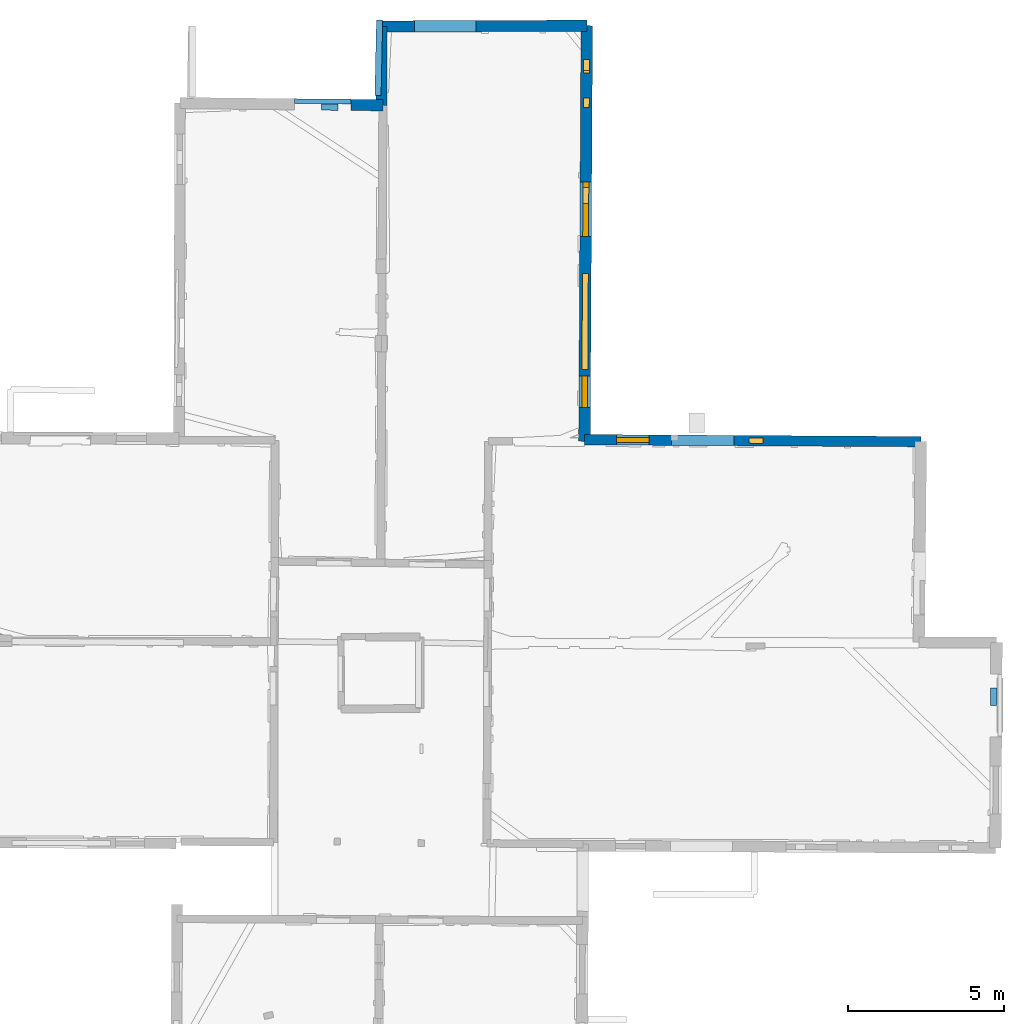
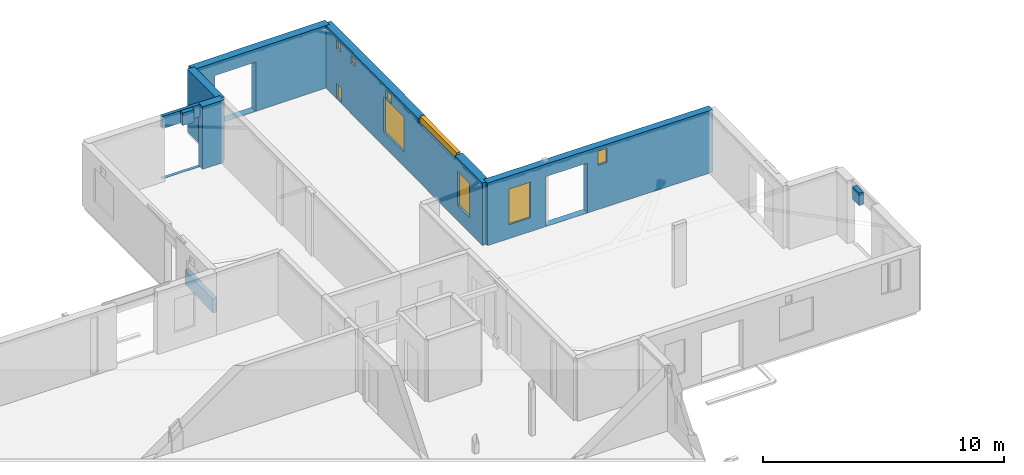
# One storey, part 11 of 17: 9 walls, 9 windows, 12 openings.
"""IFC2X3 building model written with IfcOpenShell, lengths in metres."""

from ifc_helpers import new_model, entity, si_unit, converted_unit, derived_unit, direction, frame, frame_2d, origin, origin_2d_with_axis, place, context, subcontext, project, spatial, polyline, rectangle, outline, extrude, source, transform, mapped, material, layer, layer_set, layer_usage, type_object, type_shapes, element, fill, save


model = new_model("IFC2X3")

# Units and contexts
model_context = context("Model", 3, precision=1e-05, world=origin(), true_north=direction((0.0, 1.0)))
body_context = subcontext(model_context, "Body", "Model", "MODEL_VIEW")
ifc_project = project(units=[si_unit("LENGTHUNIT", "METRE"), si_unit("AREAUNIT", "SQUARE_METRE"), si_unit("VOLUMEUNIT", "CUBIC_METRE"), converted_unit("PLANEANGLEUNIT", "DEGREE", entity("IfcRatioMeasure", 0.0174532925199433), si_unit("PLANEANGLEUNIT", "RADIAN"), dimensions=[0, 0, 0, 0, 0, 0, 0]), si_unit("MASSUNIT", "GRAM", prefix="KILO"), derived_unit("MASSDENSITYUNIT", [(si_unit("MASSUNIT", "GRAM", prefix="KILO"), 1), (si_unit("LENGTHUNIT", "METRE"), -3)]), derived_unit("MOMENTOFINERTIAUNIT", [(si_unit("LENGTHUNIT", "METRE"), 4)]), si_unit("TIMEUNIT", "SECOND"), si_unit("FREQUENCYUNIT", "HERTZ"), si_unit("THERMODYNAMICTEMPERATUREUNIT", "DEGREE_CELSIUS"), derived_unit("THERMALTRANSMITTANCEUNIT", [(si_unit("MASSUNIT", "GRAM", prefix="KILO"), 1), (si_unit("THERMODYNAMICTEMPERATUREUNIT", "KELVIN"), -1), (si_unit("TIMEUNIT", "SECOND"), -3)]), derived_unit("VOLUMETRICFLOWRATEUNIT", [(si_unit("LENGTHUNIT", "METRE"), 3), (si_unit("TIMEUNIT", "SECOND"), -1)]), si_unit("ELECTRICCURRENTUNIT", "AMPERE"), si_unit("ELECTRICVOLTAGEUNIT", "VOLT"), si_unit("POWERUNIT", "WATT"), si_unit("FORCEUNIT", "NEWTON", prefix="KILO"), si_unit("ILLUMINANCEUNIT", "LUX"), si_unit("LUMINOUSFLUXUNIT", "LUMEN"), si_unit("LUMINOUSINTENSITYUNIT", "CANDELA"), derived_unit("USERDEFINED", [(si_unit("MASSUNIT", "GRAM", prefix="KILO"), -1), (si_unit("LENGTHUNIT", "METRE"), -2), (si_unit("TIMEUNIT", "SECOND"), 3), (si_unit("LUMINOUSFLUXUNIT", "LUMEN"), 1)]), derived_unit("LINEARVELOCITYUNIT", [(si_unit("LENGTHUNIT", "METRE"), 1), (si_unit("TIMEUNIT", "SECOND"), -1)]), si_unit("PRESSUREUNIT", "PASCAL"), derived_unit("USERDEFINED", [(si_unit("LENGTHUNIT", "METRE"), -2), (si_unit("MASSUNIT", "GRAM", prefix="KILO"), 1), (si_unit("TIMEUNIT", "SECOND"), -2)]), derived_unit("LINEARFORCEUNIT", [(si_unit("MASSUNIT", "GRAM", prefix="KILO"), 1), (si_unit("LENGTHUNIT", "METRE"), 1), (si_unit("TIMEUNIT", "SECOND"), -2), (si_unit("LENGTHUNIT", "METRE"), -1)]), derived_unit("PLANARFORCEUNIT", [(si_unit("MASSUNIT", "GRAM", prefix="KILO"), 1), (si_unit("LENGTHUNIT", "METRE"), 1), (si_unit("TIMEUNIT", "SECOND"), -2), (si_unit("LENGTHUNIT", "METRE"), -2)])], contexts=[model_context])

# Site, building, storey
placement_1 = place(None, origin())
site = spatial("IfcSite", under=ifc_project, at=placement_1, CompositionType="ELEMENT")
building = spatial("IfcBuilding", under=site, at=placement_1, CompositionType="ELEMENT")
storey_placement = place(placement_1, frame((0.0, 0.0, 5.56662893295288)))
storey = spatial("IfcBuildingStorey", under=building, at=storey_placement, Name="Level 3", CompositionType="ELEMENT", Elevation=5.56662893295288)

# Wall, openings, windows
ifc_material_1 = material(Name="Default wall")
ifc_layer_1 = layer(ifc_material_1, 0.330000013113022)
ifc_layer_set_1 = layer_set([ifc_layer_1], Name="wall_thickness_0.3300")
ifc_layer_usage_1 = layer_usage(ifc_layer_set_1, "AXIS2", "POSITIVE", -0.165000006556511)
wall_type_1 = type_object("IfcWallType", Name="wall_thickness_0.3300", PredefinedType="STANDARD", material=ifc_layer_set_1)
wall_1_placement = place(storey_placement, frame((12.8773711844642, 64.0986976332287, 0.0), z_axis=(0.0, 0.0, 1.0), x_axis=(0.999982570986053, -0.00590404303195194, 0.0)))
wall_1 = element("IfcWallStandardCase", 1, at=wall_1_placement, inside=storey, type_object=wall_type_1, material=ifc_layer_usage_1, Name="Wall:4", ObjectType="Wall", context=body_context, shape_type="SweptSolid", body=[
    extrude(outline(polyline([(10.7565408541965, -0.165000006556511), (10.7565408541965, 0.165000006556511), (0.0, 0.165000006556511), (0.0, -0.165000006556511), (10.7565408541965, -0.165000006556511)])), origin(), (0.0, 0.0, 1.0), 3.16489877700806),
])
opening_1_placement = place(wall_1_placement, frame((2.78610426003413, -0.165000006556511, 0.00537109375)))
element("IfcOpeningElement", 2, at=opening_1_placement, cuts=wall_1, Name="Opening : 1990 x 2520 : 3", ObjectType="Opening", context=body_context, shape_type="SweptSolid", body=[
    extrude(rectangle(XDim=1.99, YDim=2.52, at=frame_2d((1.26, 0.995), x_axis=(0.0, 1.0))), frame((0.0, 0.0, 0.0), z_axis=(0.0, 1.0, 0.0), x_axis=(0.0, 0.0, 1.0)), (0.0, 0.0, 1.0), 0.330000013113022),
])
opening_2_placement = place(wall_1_placement, frame((5.26524771907873, -0.165000006556511, 2.23937082290649)))
opening_2 = element("IfcOpeningElement", 3, at=opening_2_placement, cuts=wall_1, Name="Opening : 445 x 720 : 4", ObjectType="Opening", context=body_context, shape_type="SweptSolid", body=[
    extrude(rectangle(XDim=0.445, YDim=0.72, at=frame_2d((0.36, 0.2225), x_axis=(0.0, 1.0))), frame((0.0, 0.0, 0.0), z_axis=(0.0, 1.0, 0.0), x_axis=(0.0, 0.0, 1.0)), (0.0, 0.0, 1.0), 0.330000013113022),
])
opening_3_placement = place(wall_1_placement, frame((1.02610387296639, -0.165000006556511, 0.705370903015137)))
opening_3 = element("IfcOpeningElement", 4, at=opening_3_placement, cuts=wall_1, Name="Opening : 1035 x 1805 : 5", ObjectType="Opening", context=body_context, shape_type="SweptSolid", body=[
    extrude(rectangle(XDim=1.035, YDim=1.805, at=frame_2d((0.9025, 0.5175), x_axis=(0.0, 1.0))), frame((0.0, 0.0, 0.0), z_axis=(0.0, 1.0, 0.0), x_axis=(0.0, 0.0, 1.0)), (0.0, 0.0, 1.0), 0.330000013113022),
])
ifc_material_2 = material(Name="Window Default")
window_style_1 = type_object("IfcWindowStyle", Name="Window : 445 x 720mm", ConstructionType="NOTDEFINED", OperationType="NOTDEFINED", ParameterTakesPrecedence=False, Sizeable=False, material=ifc_material_2)
shared_shape_1 = source(origin(), body_context, "Body", "SweptSolid", [
    extrude(rectangle(XDim=0.165000006556511, YDim=0.445, at=origin_2d_with_axis()), frame((0.2225, 0.165000006556511, 0.0), z_axis=(0.0, 0.0, 1.0), x_axis=(0.0, 1.0, 0.0)), (0.0, 0.0, 1.0), 0.72),
])
type_shapes(window_style_1, [shared_shape_1])
window_1_placement = place(opening_2_placement, origin())
window_1 = element("IfcWindow", 5, at=window_1_placement, inside=storey, type_object=window_style_1, Name="Window : 445 x 720mm : 1", ObjectType="Window : 445 x 720mm", OverallHeight=0.72, OverallWidth=0.445, context=body_context, shape_type="MappedRepresentation", body=[
    mapped(shared_shape_1, transform((0.0, 0.0, 0.0), scale=1.0)),
])
fill(opening_2, window_1)
window_style_2 = type_object("IfcWindowStyle", Name="Window : 1035 x 1805mm", ConstructionType="NOTDEFINED", OperationType="NOTDEFINED", ParameterTakesPrecedence=False, Sizeable=False, material=ifc_material_2)
shared_shape_2 = source(origin(), body_context, "Body", "SweptSolid", [
    extrude(rectangle(XDim=0.165000006556511, YDim=1.035, at=origin_2d_with_axis()), frame((0.5175, 0.165000006556511, 0.0), z_axis=(0.0, 0.0, 1.0), x_axis=(0.0, 1.0, 0.0)), (0.0, 0.0, 1.0), 1.805),
])
type_shapes(window_style_2, [shared_shape_2])
window_2_placement = place(opening_3_placement, origin())
window_2 = element("IfcWindow", 6, at=window_2_placement, inside=storey, type_object=window_style_2, Name="Window : 1035 x 1805mm : 2", ObjectType="Window : 1035 x 1805mm", OverallHeight=1.805, OverallWidth=1.035, context=body_context, shape_type="MappedRepresentation", body=[
    mapped(shared_shape_2, transform((0.0, 0.0, 0.0), scale=1.0)),
])
fill(opening_3, window_2)

# Walls
ifc_layer_2 = layer(ifc_material_1, 0.2)
ifc_layer_set_2 = layer_set([ifc_layer_2], Name="wall_thickness_0.2000")
ifc_layer_usage_2 = layer_usage(ifc_layer_set_2, "AXIS2", "POSITIVE", -0.1)
wall_type_2 = type_object("IfcWallType", Name="wall_thickness_0.2000", PredefinedType="STANDARD", material=ifc_layer_set_2)
placement_2 = place(placement_1, frame((0.0, 0.0, 8.09899997711182)))
wall_2_placement = place(placement_2, frame((25.9651642169775, 56.1576721431033, 0.0), z_axis=(0.0, 0.0, 1.0), x_axis=(-0.00824713523996844, -0.999965991801888, 0.0)))
element("IfcWallStandardCase", 7, at=wall_2_placement, inside=storey, type_object=wall_type_2, material=ifc_layer_usage_2, Name="Wall:55", ObjectType="Wall", context=body_context, shape_type="SweptSolid", body=[
    extrude(outline(polyline([(0.565002582639686, -0.1), (0.565002582639686, 0.1), (0.0, 0.1), (0.0, -0.1), (0.565002582639686, -0.1)])), origin(), (0.0, 0.0, 1.0), 0.632527732849121),
])
placement_3 = place(placement_1, frame((0.0, 0.0, 8.09899997711182)))
wall_3_placement = place(placement_3, frame((4.46161637524868, 74.7364073292613, 0.0), z_axis=(0.0, 0.0, 1.0), x_axis=(0.999937550432518, -0.0111756536728691, 0.0)))
element("IfcWallStandardCase", 8, at=wall_3_placement, inside=storey, type_object=wall_type_2, material=ifc_layer_usage_2, Name="Wall:91", ObjectType="Wall", context=body_context, shape_type="SweptSolid", body=[
    extrude(outline(polyline([(0.539999829170567, -0.1), (0.539999829170567, 0.1), (0.0, 0.1), (0.0, -0.1), (0.539999829170567, -0.1)])), origin(), (0.0, 0.0, 1.0), 0.632527732849121),
])
placement_4 = place(placement_1, frame((0.0, 0.0, -2.2819995880127)))
wall_4_placement = place(placement_4, frame((6.32514802864819, 77.5169268311821, 0.0), z_axis=(0.0, 0.0, 1.0), x_axis=(-0.0216953788022225, -0.999764627569223, 0.0)))
element("IfcWallStandardCase", 9, at=wall_4_placement, inside=storey, type_object=wall_type_2, material=ifc_layer_usage_2, Name="Wall:854", ObjectType="Wall", context=body_context, shape_type="SweptSolid", body=[
    extrude(outline(polyline([(2.40779329065963, -0.1), (2.40779329065963, 0.1), (0.0, 0.1), (0.0, -0.1), (2.40779329065963, -0.1)])), origin(), (0.0, 0.0, 1.0), 0.720746183395386),
])
ifc_layer_3 = layer(ifc_material_1, 0.340000003576279)
ifc_layer_set_3 = layer_set([ifc_layer_3], Name="wall_thickness_0.3400")
ifc_layer_usage_3 = layer_usage(ifc_layer_set_3, "AXIS2", "POSITIVE", -0.170000001788139)
wall_type_3 = type_object("IfcWallType", Name="wall_thickness_0.3400", PredefinedType="STANDARD", material=ifc_layer_set_3)
wall_5_placement = place(storey_placement, frame((6.39823967766986, 77.3114271906475, 0.0), z_axis=(0.0, 0.0, 1.0), x_axis=(-0.00456062519570914, -0.999989600294835, 0.0)))
element("IfcWallStandardCase", 10, at=wall_5_placement, inside=storey, type_object=wall_type_3, material=ifc_layer_usage_3, Name="Wall:76", ObjectType="Wall", context=body_context, shape_type="SweptSolid", body=[
    extrude(outline(polyline([(2.5181078526183, -0.170000001788139), (2.5181078526183, 0.170000001788139), (0.0, 0.170000001788139), (0.0, -0.170000001788139), (2.5181078526183, -0.170000001788139)])), origin(), (0.0, 0.0, 1.0), 3.16489877700806),
])

# Wall, openings, windows
ifc_layer_4 = layer(ifc_material_1, 0.370000004768372)
ifc_layer_set_4 = layer_set([ifc_layer_4], Name="wall_thickness_0.3700")
ifc_layer_usage_4 = layer_usage(ifc_layer_set_4, "AXIS2", "POSITIVE", -0.185000002384186)
wall_type_4 = type_object("IfcWallType", Name="wall_thickness_0.3700", PredefinedType="STANDARD", material=ifc_layer_set_4)
wall_6_placement = place(storey_placement, frame((12.9516491807807, 77.3358998229624, 0.0), z_axis=(0.0, 0.0, 1.0), x_axis=(-0.00561111046554044, -0.99998425759576, 0.0)))
wall_6 = element("IfcWallStandardCase", 11, at=wall_6_placement, inside=storey, type_object=wall_type_4, material=ifc_layer_usage_4, Name="Wall:56", ObjectType="Wall", context=body_context, shape_type="SweptSolid", body=[
    extrude(outline(polyline([(13.2879517990548, -0.185000002384186), (13.2879517990548, 0.185000002384186), (0.0, 0.185000002384186), (0.0, -0.185000002384186), (13.2879517990548, -0.185000002384186)])), origin(), (0.0, 0.0, 1.0), 3.16489877700806),
])
opening_4_placement = place(wall_6_placement, frame((5.00130707688883, -0.185000002384186, 0.730370998382568)))
opening_4 = element("IfcOpeningElement", 12, at=opening_4_placement, cuts=wall_6, Name="Opening : 1735 x 1775 : 50", ObjectType="Opening", context=body_context, shape_type="SweptSolid", body=[
    extrude(rectangle(XDim=1.735, YDim=1.775, at=frame_2d((0.8875, 0.8675), x_axis=(0.0, 1.0))), frame((0.0, 0.0, 0.0), z_axis=(0.0, 1.0, 0.0), x_axis=(0.0, 0.0, 1.0)), (0.0, 0.0, 1.0), 0.370000004768372),
])
opening_5_placement = place(wall_6_placement, frame((2.30637939877338, -0.185000002384186, 2.57537126541138)))
opening_5 = element("IfcOpeningElement", 13, at=opening_5_placement, cuts=wall_6, Name="Opening : 305 x 380 : 51", ObjectType="Opening", context=body_context, shape_type="SweptSolid", body=[
    extrude(rectangle(XDim=0.305, YDim=0.38, at=frame_2d((0.19, 0.1525), x_axis=(0.0, 1.0))), frame((0.0, 0.0, 0.0), z_axis=(0.0, 1.0, 0.0), x_axis=(0.0, 0.0, 1.0)), (0.0, 0.0, 1.0), 0.370000004768372),
])
opening_6_placement = place(wall_6_placement, frame((5.1777014561399, -0.185000002384186, 2.54537057876587)))
opening_6 = element("IfcOpeningElement", 14, at=opening_6_placement, cuts=wall_6, Name="Opening : 500 x 410 : 52", ObjectType="Opening", context=body_context, shape_type="SweptSolid", body=[
    extrude(rectangle(XDim=0.5, YDim=0.41, at=frame_2d((0.205, 0.25), x_axis=(0.0, 1.0))), frame((0.0, 0.0, 0.0), z_axis=(0.0, 1.0, 0.0), x_axis=(0.0, 0.0, 1.0)), (0.0, 0.0, 1.0), 0.370000004768372),
])
opening_7_placement = place(wall_6_placement, frame((7.92630277081426, -0.185000002384186, 2.95037126541138)))
opening_7 = element("IfcOpeningElement", 15, at=opening_7_placement, cuts=wall_6, Name="Opening : 3060 x 305 : 53", ObjectType="Opening", context=body_context, shape_type="SweptSolid", body=[
    extrude(rectangle(XDim=3.06, YDim=0.305, at=frame_2d((0.1525, 1.53), x_axis=(0.0, 1.0))), frame((0.0, 0.0, 0.0), z_axis=(0.0, 1.0, 0.0), x_axis=(0.0, 0.0, 1.0)), (0.0, 0.0, 1.0), 0.370000004768372),
])
opening_8_placement = place(wall_6_placement, frame((1.08137690172616, -0.185000002384186, 2.55537080764771)))
opening_8 = element("IfcOpeningElement", 16, at=opening_8_placement, cuts=wall_6, Name="Opening : 345 x 435 : 54", ObjectType="Opening", context=body_context, shape_type="SweptSolid", body=[
    extrude(rectangle(XDim=0.345, YDim=0.435, at=frame_2d((0.2175, 0.1725), x_axis=(0.0, 1.0))), frame((0.0, 0.0, 0.0), z_axis=(0.0, 1.0, 0.0), x_axis=(0.0, 0.0, 1.0)), (0.0, 0.0, 1.0), 0.370000004768372),
])
opening_9_placement = place(wall_6_placement, frame((1.09637652615127, -0.185000002384186, 0.0803709030151367)))
opening_9 = element("IfcOpeningElement", 17, at=opening_9_placement, cuts=wall_6, Name="Opening : 410 x 720 : 55", ObjectType="Opening", context=body_context, shape_type="SweptSolid", body=[
    extrude(rectangle(XDim=0.41, YDim=0.72, at=frame_2d((0.36, 0.205), x_axis=(0.0, 1.0))), frame((0.0, 0.0, 0.0), z_axis=(0.0, 1.0, 0.0), x_axis=(0.0, 0.0, 1.0)), (0.0, 0.0, 1.0), 0.370000004768372),
])
opening_10_placement = place(wall_6_placement, frame((11.2063074063139, -0.185000002384186, 0.770370960235596)))
opening_10 = element("IfcOpeningElement", 18, at=opening_10_placement, cuts=wall_6, Name="Opening : 1000 x 1740 : 56", ObjectType="Opening", context=body_context, shape_type="SweptSolid", body=[
    extrude(rectangle(XDim=1.0, YDim=1.74, at=frame_2d((0.87, 0.5), x_axis=(0.0, 1.0))), frame((0.0, 0.0, 0.0), z_axis=(0.0, 1.0, 0.0), x_axis=(0.0, 0.0, 1.0)), (0.0, 0.0, 1.0), 0.370000004768372),
])
window_style_3 = type_object("IfcWindowStyle", Name="Window : 1735 x 1775mm", ConstructionType="NOTDEFINED", OperationType="NOTDEFINED", ParameterTakesPrecedence=False, Sizeable=False, material=ifc_material_2)
shared_shape_3 = source(origin(), body_context, "Body", "SweptSolid", [
    extrude(rectangle(XDim=0.185000002384186, YDim=1.735, at=origin_2d_with_axis()), frame((0.8675, 0.185000002384186, 0.0), z_axis=(0.0, 0.0, 1.0), x_axis=(0.0, 1.0, 0.0)), (0.0, 0.0, 1.0), 1.775),
])
type_shapes(window_style_3, [shared_shape_3])
window_3_placement = place(opening_4_placement, origin())
window_3 = element("IfcWindow", 19, at=window_3_placement, inside=storey, type_object=window_style_3, Name="Window : 1735 x 1775mm : 28", ObjectType="Window : 1735 x 1775mm", OverallHeight=1.775, OverallWidth=1.735, context=body_context, shape_type="MappedRepresentation", body=[
    mapped(shared_shape_3, transform((0.0, 0.0, 0.0), scale=1.0)),
])
fill(opening_4, window_3)
window_style_4 = type_object("IfcWindowStyle", Name="Window : 305 x 380mm", ConstructionType="NOTDEFINED", OperationType="NOTDEFINED", ParameterTakesPrecedence=False, Sizeable=False, material=ifc_material_2)
shared_shape_4 = source(origin(), body_context, "Body", "SweptSolid", [
    extrude(rectangle(XDim=0.185000002384186, YDim=0.305, at=origin_2d_with_axis()), frame((0.1525, 0.185000002384186, 0.0), z_axis=(0.0, 0.0, 1.0), x_axis=(0.0, 1.0, 0.0)), (0.0, 0.0, 1.0), 0.38),
])
type_shapes(window_style_4, [shared_shape_4])
window_4_placement = place(opening_5_placement, origin())
window_4 = element("IfcWindow", 20, at=window_4_placement, inside=storey, type_object=window_style_4, Name="Window : 305 x 380mm : 29", ObjectType="Window : 305 x 380mm", OverallHeight=0.38, OverallWidth=0.305, context=body_context, shape_type="MappedRepresentation", body=[
    mapped(shared_shape_4, transform((0.0, 0.0, 0.0), scale=1.0)),
])
fill(opening_5, window_4)
window_style_5 = type_object("IfcWindowStyle", Name="Window : 500 x 410mm", ConstructionType="NOTDEFINED", OperationType="NOTDEFINED", ParameterTakesPrecedence=False, Sizeable=False, material=ifc_material_2)
shared_shape_5 = source(origin(), body_context, "Body", "SweptSolid", [
    extrude(rectangle(XDim=0.185000002384186, YDim=0.5, at=origin_2d_with_axis()), frame((0.25, 0.185000002384186, 0.0), z_axis=(0.0, 0.0, 1.0), x_axis=(0.0, 1.0, 0.0)), (0.0, 0.0, 1.0), 0.41),
])
type_shapes(window_style_5, [shared_shape_5])
window_5_placement = place(opening_6_placement, origin())
window_5 = element("IfcWindow", 21, at=window_5_placement, inside=storey, type_object=window_style_5, Name="Window : 500 x 410mm : 30", ObjectType="Window : 500 x 410mm", OverallHeight=0.41, OverallWidth=0.5, context=body_context, shape_type="MappedRepresentation", body=[
    mapped(shared_shape_5, transform((0.0, 0.0, 0.0), scale=1.0)),
])
fill(opening_6, window_5)
window_style_6 = type_object("IfcWindowStyle", Name="Window : 3060 x 305mm", ConstructionType="NOTDEFINED", OperationType="NOTDEFINED", ParameterTakesPrecedence=False, Sizeable=False, material=ifc_material_2)
shared_shape_6 = source(origin(), body_context, "Body", "SweptSolid", [
    extrude(rectangle(XDim=0.185000002384186, YDim=3.06, at=origin_2d_with_axis()), frame((1.53, 0.185000002384186, 0.0), z_axis=(0.0, 0.0, 1.0), x_axis=(0.0, 1.0, 0.0)), (0.0, 0.0, 1.0), 0.305),
])
type_shapes(window_style_6, [shared_shape_6])
window_6_placement = place(opening_7_placement, origin())
window_6 = element("IfcWindow", 22, at=window_6_placement, inside=storey, type_object=window_style_6, Name="Window : 3060 x 305mm : 31", ObjectType="Window : 3060 x 305mm", OverallHeight=0.305, OverallWidth=3.06, context=body_context, shape_type="MappedRepresentation", body=[
    mapped(shared_shape_6, transform((0.0, 0.0, 0.0), scale=1.0)),
])
fill(opening_7, window_6)
window_style_7 = type_object("IfcWindowStyle", Name="Window : 345 x 435mm", ConstructionType="NOTDEFINED", OperationType="NOTDEFINED", ParameterTakesPrecedence=False, Sizeable=False, material=ifc_material_2)
shared_shape_7 = source(origin(), body_context, "Body", "SweptSolid", [
    extrude(rectangle(XDim=0.185000002384186, YDim=0.345, at=origin_2d_with_axis()), frame((0.1725, 0.185000002384186, 0.0), z_axis=(0.0, 0.0, 1.0), x_axis=(0.0, 1.0, 0.0)), (0.0, 0.0, 1.0), 0.435),
])
type_shapes(window_style_7, [shared_shape_7])
window_7_placement = place(opening_8_placement, origin())
window_7 = element("IfcWindow", 23, at=window_7_placement, inside=storey, type_object=window_style_7, Name="Window : 345 x 435mm : 32", ObjectType="Window : 345 x 435mm", OverallHeight=0.435, OverallWidth=0.345, context=body_context, shape_type="MappedRepresentation", body=[
    mapped(shared_shape_7, transform((0.0, 0.0, 0.0), scale=1.0)),
])
fill(opening_8, window_7)
window_style_8 = type_object("IfcWindowStyle", Name="Window : 410 x 720mm", ConstructionType="NOTDEFINED", OperationType="NOTDEFINED", ParameterTakesPrecedence=False, Sizeable=False, material=ifc_material_2)
shared_shape_8 = source(origin(), body_context, "Body", "SweptSolid", [
    extrude(rectangle(XDim=0.185000002384186, YDim=0.41, at=origin_2d_with_axis()), frame((0.205, 0.185000002384186, 0.0), z_axis=(0.0, 0.0, 1.0), x_axis=(0.0, 1.0, 0.0)), (0.0, 0.0, 1.0), 0.72),
])
type_shapes(window_style_8, [shared_shape_8])
window_8_placement = place(opening_9_placement, origin())
window_8 = element("IfcWindow", 24, at=window_8_placement, inside=storey, type_object=window_style_8, Name="Window : 410 x 720mm : 33", ObjectType="Window : 410 x 720mm", OverallHeight=0.72, OverallWidth=0.41, context=body_context, shape_type="MappedRepresentation", body=[
    mapped(shared_shape_8, transform((0.0, 0.0, 0.0), scale=1.0)),
])
fill(opening_9, window_8)
window_style_9 = type_object("IfcWindowStyle", Name="Window : 1000 x 1740mm", ConstructionType="NOTDEFINED", OperationType="NOTDEFINED", ParameterTakesPrecedence=False, Sizeable=False, material=ifc_material_2)
shared_shape_9 = source(origin(), body_context, "Body", "SweptSolid", [
    extrude(rectangle(XDim=0.185000002384186, YDim=1.0, at=origin_2d_with_axis()), frame((0.5, 0.185000002384186, 0.0), z_axis=(0.0, 0.0, 1.0), x_axis=(0.0, 1.0, 0.0)), (0.0, 0.0, 1.0), 1.74),
])
type_shapes(window_style_9, [shared_shape_9])
window_9_placement = place(opening_10_placement, origin())
window_9 = element("IfcWindow", 25, at=window_9_placement, inside=storey, type_object=window_style_9, Name="Window : 1000 x 1740mm : 34", ObjectType="Window : 1000 x 1740mm", OverallHeight=1.74, OverallWidth=1.0, context=body_context, shape_type="MappedRepresentation", body=[
    mapped(shared_shape_9, transform((0.0, 0.0, 0.0), scale=1.0)),
])
fill(opening_10, window_9)

# Wall, opening
ifc_layer_5 = layer(ifc_material_1, 0.360000014305115)
ifc_layer_set_5 = layer_set([ifc_layer_5], Name="wall_thickness_0.3600")
ifc_layer_usage_5 = layer_usage(ifc_layer_set_5, "AXIS2", "POSITIVE", -0.180000007152557)
wall_type_5 = type_object("IfcWallType", Name="wall_thickness_0.3600", PredefinedType="STANDARD", material=ifc_layer_set_5)
wall_7_placement = place(storey_placement, frame((6.39823985338717, 77.3114181805749, 0.0), z_axis=(0.0, 0.0, 1.0), x_axis=(0.99999301733862, 0.00373701404893613, 0.0)))
wall_7 = element("IfcWallStandardCase", 26, at=wall_7_placement, inside=storey, type_object=wall_type_5, material=ifc_layer_usage_5, Name="Wall:89", ObjectType="Wall", context=body_context, shape_type="SweptSolid", body=[
    extrude(outline(polyline([(6.55345581381599, -0.180000007152557), (6.55345581381599, 0.180000007152557), (0.0, 0.180000007152557), (0.0, -0.180000007152557), (6.55345581381599, -0.180000007152557)])), origin(), (0.0, 0.0, 1.0), 3.16489877700806),
])
opening_11_placement = place(wall_7_placement, frame((1.04196379963944, -0.180000007152557, 0.00537109375)))
element("IfcOpeningElement", 27, at=opening_11_placement, cuts=wall_7, Name="Opening : 1965 x 2490 : 80", ObjectType="Opening", context=body_context, shape_type="SweptSolid", body=[
    extrude(rectangle(XDim=1.965, YDim=2.49, at=frame_2d((1.245, 0.9825), x_axis=(0.0, 1.0))), frame((0.0, 0.0, 0.0), z_axis=(0.0, 1.0, 0.0), x_axis=(0.0, 0.0, 1.0)), (0.0, 0.0, 1.0), 0.360000014305115),
])

# Wall
wall_8_placement = place(storey_placement, frame((5.40904146822307, 74.803981267191, 0.0), z_axis=(0.0, 0.0, 1.0), x_axis=(0.999940881963553, -0.0108734804892863, 0.0)))
element("IfcWallStandardCase", 28, at=wall_8_placement, inside=storey, type_object=wall_type_5, material=ifc_layer_usage_5, Name="Wall:120", ObjectType="Wall", context=body_context, shape_type="SweptSolid", body=[
    extrude(outline(polyline([(1.02230632068398, -0.180000007152557), (1.02230632068398, 0.180000007152557), (0.0, 0.180000007152557), (0.0, -0.180000007152557), (1.02230632068398, -0.180000007152557)])), origin(), (0.0, 0.0, 1.0), 3.16489877700806),
])

# Wall, opening
ifc_layer_6 = layer(ifc_material_1, 0.150000005960464)
ifc_layer_set_6 = layer_set([ifc_layer_6], Name="wall_thickness_0.1500")
ifc_layer_usage_6 = layer_usage(ifc_layer_set_6, "AXIS2", "POSITIVE", -0.0750000029802322)
wall_type_6 = type_object("IfcWallType", Name="wall_thickness_0.1500", PredefinedType="STANDARD", material=ifc_layer_set_6)
wall_9_placement = place(storey_placement, frame((3.61091288828042, 74.9262937267081, 0.0), z_axis=(0.0, 0.0, 1.0), x_axis=(0.999976706681597, -0.00682540066422498, 0.0)))
wall_9 = element("IfcWallStandardCase", 29, at=wall_9_placement, inside=storey, type_object=wall_type_6, material=ifc_layer_usage_6, Name="Wall:94", ObjectType="Wall", context=body_context, shape_type="SweptSolid", body=[
    extrude(outline(polyline([(1.79964895829412, -0.0750000029802322), (1.79964895829412, 0.0750000029802322), (0.0, 0.0750000029802322), (0.0, -0.0750000029802322), (1.79964895829412, -0.0750000029802322)])), origin(), (0.0, 0.0, 1.0), 3.16489877700806),
])
opening_12_placement = place(wall_9_placement, frame((-0.0902016555086373, -0.0750000029802322, 0.00537109375)))
element("IfcOpeningElement", 30, at=opening_12_placement, cuts=wall_9, Name="Opening : 1970 x 2535 : 82", ObjectType="Opening", context=body_context, shape_type="SweptSolid", body=[
    extrude(rectangle(XDim=1.97, YDim=2.535, at=frame_2d((1.2675, 0.985), x_axis=(0.0, 1.0))), frame((0.0, 0.0, 0.0), z_axis=(0.0, 1.0, 0.0), x_axis=(0.0, 0.0, 1.0)), (0.0, 0.0, 1.0), 0.150000005960464),
])

save(model, "model.ifc")
